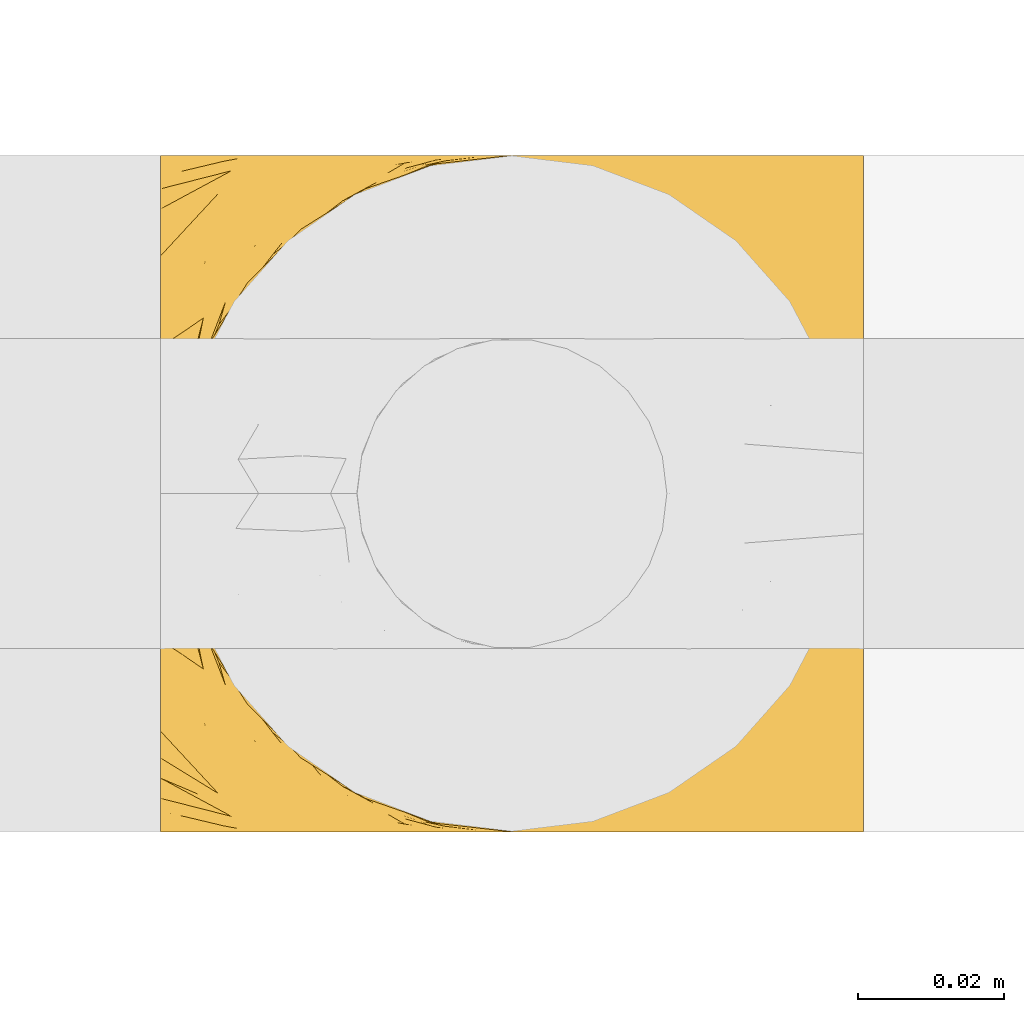
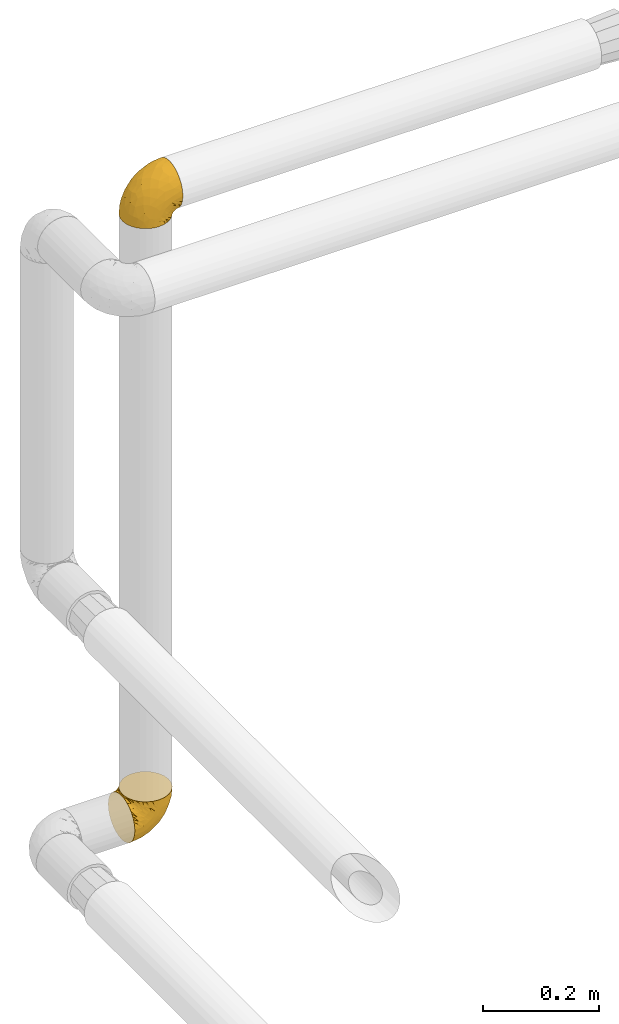
# One storey, part 132 of 827: 2 coverings.
"""IFC2X3 building model written with IfcOpenShell, lengths in millimetres."""

from ifc_helpers import new_model, entity, si_unit, converted_unit, derived_unit, direction, frame, origin, place, context, subcontext, project, spatial, faceted_brep, element, save


model = new_model("IFC2X3")

# Units and contexts
model_context = context("Model", 3, precision=0.01, world=origin(), true_north=direction((6.12303176911189e-17, 1.0)))
body_context = subcontext(model_context, "Body", "Model", "MODEL_VIEW")
ifc_project = project(units=[si_unit("LENGTHUNIT", "METRE", prefix="MILLI"), si_unit("AREAUNIT", "SQUARE_METRE"), si_unit("VOLUMEUNIT", "CUBIC_METRE"), converted_unit("PLANEANGLEUNIT", "DEGREE", entity("IfcRatioMeasure", 0.0174532925199433), si_unit("PLANEANGLEUNIT", "RADIAN"), dimensions=[0, 0, 0, 0, 0, 0, 0]), si_unit("MASSUNIT", "GRAM", prefix="KILO"), derived_unit("MASSDENSITYUNIT", [(si_unit("MASSUNIT", "GRAM", prefix="KILO"), 1), (si_unit("LENGTHUNIT", "METRE"), -3)]), derived_unit("MOMENTOFINERTIAUNIT", [(si_unit("LENGTHUNIT", "METRE"), 4)]), si_unit("TIMEUNIT", "SECOND"), si_unit("FREQUENCYUNIT", "HERTZ"), si_unit("THERMODYNAMICTEMPERATUREUNIT", "DEGREE_CELSIUS"), derived_unit("THERMALTRANSMITTANCEUNIT", [(si_unit("MASSUNIT", "GRAM", prefix="KILO"), 1), (si_unit("THERMODYNAMICTEMPERATUREUNIT", "KELVIN"), -1), (si_unit("TIMEUNIT", "SECOND"), -3)]), derived_unit("VOLUMETRICFLOWRATEUNIT", [(si_unit("LENGTHUNIT", "METRE"), 3), (si_unit("TIMEUNIT", "SECOND"), -1)]), derived_unit("MASSFLOWRATEUNIT", [(si_unit("MASSUNIT", "GRAM", prefix="KILO"), 1), (si_unit("TIMEUNIT", "SECOND"), -1)]), derived_unit("ROTATIONALFREQUENCYUNIT", [(si_unit("TIMEUNIT", "SECOND"), -1)]), si_unit("ELECTRICCURRENTUNIT", "AMPERE"), si_unit("ELECTRICVOLTAGEUNIT", "VOLT"), si_unit("POWERUNIT", "WATT"), si_unit("FORCEUNIT", "NEWTON", prefix="KILO"), si_unit("ILLUMINANCEUNIT", "LUX"), si_unit("LUMINOUSFLUXUNIT", "LUMEN"), si_unit("LUMINOUSINTENSITYUNIT", "CANDELA"), derived_unit("USERDEFINED", [(si_unit("MASSUNIT", "GRAM", prefix="KILO"), -1), (si_unit("LENGTHUNIT", "METRE"), -2), (si_unit("TIMEUNIT", "SECOND"), 3), (si_unit("LUMINOUSFLUXUNIT", "LUMEN"), 1)]), derived_unit("LINEARVELOCITYUNIT", [(si_unit("LENGTHUNIT", "METRE"), 1), (si_unit("TIMEUNIT", "SECOND"), -1)]), si_unit("PRESSUREUNIT", "PASCAL"), derived_unit("USERDEFINED", [(si_unit("LENGTHUNIT", "METRE"), -2), (si_unit("MASSUNIT", "GRAM", prefix="KILO"), 1), (si_unit("TIMEUNIT", "SECOND"), -2)]), derived_unit("LINEARFORCEUNIT", [(si_unit("MASSUNIT", "GRAM", prefix="KILO"), 1), (si_unit("LENGTHUNIT", "METRE"), 1), (si_unit("TIMEUNIT", "SECOND"), -2), (si_unit("LENGTHUNIT", "METRE"), -1)]), derived_unit("PLANARFORCEUNIT", [(si_unit("MASSUNIT", "GRAM", prefix="KILO"), 1), (si_unit("LENGTHUNIT", "METRE"), 1), (si_unit("TIMEUNIT", "SECOND"), -2), (si_unit("LENGTHUNIT", "METRE"), -2)])], contexts=[model_context])

# Site, building, storey
site_placement = place(None, origin())
site = spatial("IfcSite", under=ifc_project, at=site_placement, CompositionType="ELEMENT")
building_placement = place(site_placement, origin())
building = spatial("IfcBuilding", under=site, at=building_placement, CompositionType="ELEMENT")
storey_placement = place(building_placement, frame((0.0, 0.0, 28200.0)))
storey = spatial("IfcBuildingStorey", under=building, at=storey_placement, Name="08", CompositionType="ELEMENT", Elevation=28200.0)

# Coverings
covering_1_placement = place(storey_placement, frame((12158.15, 18965.67, 2950.4)))
element("IfcCovering", 1, at=covering_1_placement, inside=storey, Name=":ADSK_", ObjectType=":ADSK_", PredefinedType="INSULATION", context=body_context, shape_type="Brep", body=[
    faceted_brep([(18.98, 11.68, 1.6), (11.67, 19.0, 1.6), (6.17, 27.76, 1.6), (2.75, 37.52, 1.6), (1.6, 47.8, 1.6), (2.75, 58.08, 1.6), (6.17, 67.85, 1.6), (11.68, 76.61, 1.6), (19.0, 83.92, 1.6), (27.76, 89.42, 1.6), (37.52, 92.84, 1.6), (47.8, 94.0, 1.6), (51.94, 93.53, 1.6), (55.01, 93.18, 1.6), (58.08, 92.84, 1.6), (62.96, 91.13, 1.6), (67.85, 89.42, 1.6), (72.23, 86.66, 1.6), (76.61, 83.91, 1.6), (80.26, 80.25, 1.6), (83.92, 76.59, 1.6), (89.42, 67.83, 1.6), (91.13, 62.95, 1.6), (92.84, 58.07, 1.6), (94.0, 47.8, 1.6), (92.84, 37.51, 1.6), (91.13, 32.63, 1.6), (89.42, 27.74, 1.6), (83.91, 18.98, 1.6), (80.25, 15.33, 1.6), (76.59, 11.67, 1.6), (72.21, 8.92, 1.6), (67.83, 6.17, 1.6), (62.95, 4.46, 1.6), (58.07, 2.75, 1.6), (55.0, 2.41, 1.6), (51.94, 2.06, 1.6), (47.8, 1.6, 1.6), (37.51, 2.75, 1.6), (27.74, 6.17, 1.6), (95.8, 47.8, 3.4), (95.8, 59.75, 4.97), (95.8, 70.9, 9.58), (95.8, 75.68, 13.26), (95.8, 80.46, 16.93), (95.8, 84.13, 21.71), (95.8, 87.81, 26.5), (95.8, 90.11, 32.07), (95.8, 92.42, 37.64), (95.8, 92.9, 41.25), (95.8, 93.17, 43.34), (95.8, 93.45, 45.42), (95.8, 94.0, 49.6), (95.8, 92.42, 61.55), (95.8, 87.81, 72.7), (95.8, 80.46, 82.26), (95.8, 70.9, 89.61), (95.8, 59.75, 94.22), (95.8, 47.8, 95.8), (95.8, 35.84, 94.22), (95.8, 24.7, 89.61), (95.8, 15.13, 82.26), (95.8, 7.78, 72.7), (95.8, 3.17, 61.55), (95.8, 1.6, 49.6), (95.8, 2.14, 45.42), (95.8, 2.69, 41.25), (95.8, 3.17, 37.64), (95.8, 5.48, 32.07), (95.8, 7.78, 26.5), (95.8, 11.46, 21.71), (95.8, 15.13, 16.93), (95.8, 19.91, 13.26), (95.8, 24.7, 9.58), (95.8, 35.84, 4.97), (60.58, 23.61, 81.55), (74.11, 31.99, 90.4), (51.59, 35.87, 83.0), (66.69, 47.8, 91.18), (76.19, 40.43, 93.13), (84.43, 47.8, 94.0), (31.2, 31.83, 66.19), (42.88, 23.37, 70.92), (79.41, 21.41, 85.95), (60.7, 3.07, 49.74), (61.85, 1.6, 35.54), (65.75, 1.6, 38.14), (69.64, 1.6, 40.74), (73.53, 1.6, 43.34), (77.43, 1.6, 45.94), (74.59, 13.45, 77.59), (54.72, 15.25, 71.17), (64.18, 8.07, 65.81), (37.94, 16.0, 59.03), (25.89, 17.34, 45.85), (34.73, 10.58, 45.79), (42.89, 5.34, 41.42), (49.83, 2.39, 34.51), (48.58, 8.36, 56.04), (22.41, 10.04, 15.15), (78.69, 2.59, 56.51), (81.64, 6.28, 68.39), (6.22, 34.28, 23.33), (12.11, 38.73, 42.86), (14.81, 27.25, 39.42), (21.61, 29.88, 53.58), (22.41, 38.6, 59.17), (30.12, 23.44, 59.06), (10.01, 25.25, 22.63), (15.36, 17.23, 20.55), (3.39, 47.8, 12.96), (19.59, 47.8, 56.96), (30.01, 47.8, 67.38), (41.19, 2.53, 18.72), (48.54, 1.6, 5.33), (49.28, 1.6, 9.07), (49.82, 1.6, 11.79), (50.37, 1.6, 14.51), (50.91, 1.6, 17.24), (51.45, 1.6, 19.96), (31.61, 5.71, 21.03), (80.15, 1.6, 46.48), (82.88, 1.6, 47.03), (85.6, 1.6, 47.57), (88.32, 1.6, 48.11), (90.19, 1.6, 48.48), (92.06, 1.6, 48.85), (6.21, 47.8, 30.7), (54.05, 1.6, 23.86), (56.65, 1.6, 27.75), (59.25, 1.6, 31.64), (24.66, 11.89, 31.26), (40.43, 47.8, 77.8), (35.17, 39.69, 72.75), (12.9, 47.8, 43.83), (53.56, 47.8, 84.49), (85.34, 13.84, 14.58), (78.44, 9.16, 16.17), (84.37, 15.79, 10.82), (89.05, 25.75, 4.64), (82.76, 16.09, 7.71), (86.31, 7.51, 25.13), (83.73, 3.99, 32.66), (77.31, 2.66, 34.94), (87.78, 3.16, 36.76), (87.91, 2.35, 40.48), (81.29, 2.23, 39.25), (93.97, 38.35, 3.69), (70.76, 6.18, 13.99), (63.67, 2.7, 21.85), (62.62, 2.93, 17.93), (90.64, 16.01, 15.11), (84.08, 9.08, 21.14), (76.28, 9.3, 12.7), (77.45, 11.68, 7.21), (88.72, 4.65, 32.27), (71.28, 3.65, 25.68), (68.09, 3.61, 22.18), (91.07, 12.8, 18.79), (57.47, 2.43, 10.12), (70.34, 6.83, 9.47), (91.35, 21.65, 10.45), (62.99, 3.7, 11.29), (94.52, 47.8, 2.87), (76.47, 3.37, 31.16), (69.96, 7.03, 6.31), (89.86, 7.87, 25.62), (78.94, 7.26, 21.18), (73.51, 3.41, 28.81), (89.62, 23.81, 7.45), (84.09, 86.5, 21.14), (86.3, 88.08, 25.13), (91.06, 82.79, 18.79), (88.32, 94.0, 48.11), (92.06, 94.0, 48.85), (82.88, 94.0, 47.03), (85.6, 94.0, 47.57), (93.97, 57.24, 3.69), (89.63, 71.76, 7.44), (50.37, 94.0, 14.51), (49.82, 94.0, 11.79), (48.54, 94.0, 5.33), (49.28, 94.0, 9.07), (82.77, 79.49, 7.71), (70.36, 88.75, 9.47), (77.31, 92.93, 34.94), (76.47, 92.22, 31.16), (69.64, 94.0, 40.74), (65.75, 94.0, 38.14), (87.78, 92.43, 36.76), (87.91, 93.24, 40.48), (89.06, 69.82, 4.63), (90.65, 79.57, 15.11), (85.35, 81.74, 14.58), (73.53, 94.0, 43.34), (77.43, 94.0, 45.94), (81.29, 93.36, 39.25), (77.46, 83.9, 7.21), (76.29, 86.28, 12.69), (57.47, 93.16, 10.14), (63.71, 92.88, 21.81), (68.11, 91.98, 22.19), (70.77, 89.41, 14.0), (71.31, 91.93, 25.69), (78.46, 86.42, 16.17), (69.52, 88.82, 6.66), (62.64, 92.66, 17.92), (91.35, 73.93, 10.45), (59.25, 94.0, 31.64), (84.6, 79.5, 10.64), (62.98, 91.89, 11.31), (51.45, 94.0, 19.96), (54.05, 94.0, 23.86), (56.65, 94.0, 27.75), (83.73, 91.6, 32.66), (80.15, 94.0, 46.48), (88.72, 90.94, 32.27), (61.85, 94.0, 35.54), (73.56, 92.16, 28.77), (78.96, 88.32, 21.17), (91.36, 86.13, 23.36), (50.91, 94.0, 17.24), (62.87, 93.2, 47.58), (76.19, 55.16, 93.13), (73.57, 82.02, 77.44), (56.07, 84.29, 66.78), (49.77, 76.94, 71.68), (44.73, 68.33, 74.96), (60.58, 71.98, 81.55), (47.64, 92.52, 36.7), (78.32, 92.9, 56.9), (51.59, 59.72, 83.0), (74.11, 63.6, 90.4), (76.04, 88.89, 67.83), (79.41, 74.18, 85.95), (14.82, 68.35, 39.41), (6.22, 61.33, 23.33), (12.12, 56.86, 42.87), (23.51, 68.62, 53.92), (31.2, 63.76, 66.19), (34.96, 72.19, 64.12), (33.86, 88.69, 33.13), (38.94, 92.19, 23.1), (30.23, 89.75, 16.98), (20.67, 59.86, 55.72), (35.17, 55.9, 72.75), (15.85, 77.99, 23.77), (22.59, 85.21, 18.41), (21.56, 74.99, 43.7), (55.94, 90.23, 54.53), (9.19, 70.75, 17.73), (25.79, 81.72, 38.98), (41.16, 86.53, 50.28), (37.95, 79.6, 59.02)], [[[0, 1, 2, 3, 4, 5, 6, 7, 8, 9, 10, 11, 12, 13, 14, 15, 16, 17, 18, 19, 20, 21, 22, 23, 24, 25, 26, 27, 28, 29, 30, 31, 32, 33, 34, 35, 36, 37, 38, 39]], [[40, 41, 42, 43, 44, 45, 46, 47, 48, 49, 50, 51, 52, 53, 54, 55, 56, 57, 58, 59, 60, 61, 62, 63, 64, 65, 66, 67, 68, 69, 70, 71, 72, 73, 74]], [[75, 76, 77]], [[78, 79, 80]], [[77, 81, 82]], [[76, 75, 83]], [[84, 85, 86, 87, 88, 89]], [[90, 91, 92]], [[76, 60, 59]], [[93, 94, 95]], [[90, 62, 61]], [[83, 61, 60]], [[96, 97, 84]], [[98, 93, 95]], [[0, 39, 99]], [[100, 84, 89]], [[62, 101, 63]], [[2, 102, 3]], [[92, 84, 100]], [[103, 102, 104]], [[103, 105, 106]], [[93, 107, 94]], [[1, 108, 2]], [[92, 101, 90]], [[108, 1, 109]], [[102, 110, 3]], [[93, 82, 107]], [[102, 108, 104]], [[111, 106, 112]], [[109, 0, 99]], [[113, 37, 114, 115, 116, 117, 118, 119]], [[120, 38, 113]], [[100, 89, 121, 122, 123, 124, 125, 126, 64]], [[127, 102, 103]], [[97, 119, 128, 129, 130, 85]], [[99, 120, 131]], [[132, 133, 77]], [[59, 80, 79]], [[1, 0, 109]], [[98, 84, 92]], [[94, 109, 131]], [[120, 39, 38]], [[93, 91, 82]], [[104, 94, 105]], [[97, 113, 119]], [[95, 120, 96]], [[83, 90, 61]], [[91, 93, 98]], [[64, 63, 100]], [[100, 63, 101]], [[77, 76, 79]], [[133, 106, 81]], [[84, 97, 85]], [[113, 96, 120]], [[113, 97, 96]], [[37, 113, 38]], [[110, 102, 127]], [[110, 4, 3]], [[103, 111, 134, 127]], [[90, 75, 91]], [[82, 81, 107]], [[91, 75, 82]], [[77, 82, 75]], [[76, 83, 60]], [[90, 83, 75]], [[105, 107, 81]], [[94, 131, 95]], [[105, 94, 107]], [[109, 94, 104]], [[120, 95, 131]], [[98, 95, 96]], [[84, 98, 96]], [[98, 92, 91]], [[106, 105, 81]], [[103, 104, 105]], [[112, 106, 133]], [[103, 106, 111]], [[112, 133, 132]], [[81, 77, 133]], [[77, 78, 135, 132]], [[120, 99, 39]], [[109, 99, 131]], [[59, 58, 80]], [[59, 79, 76]], [[90, 101, 62]], [[100, 101, 92]], [[2, 108, 102]], [[109, 104, 108]], [[78, 77, 79]], [[136, 137, 138]], [[27, 139, 140]], [[141, 142, 143]], [[144, 145, 121]], [[146, 89, 88]], [[147, 139, 25]], [[148, 149, 150]], [[136, 151, 152]], [[147, 40, 74]], [[24, 147, 25]], [[140, 153, 154]], [[33, 116, 34]], [[73, 72, 151]], [[114, 37, 36, 35, 34, 116, 115]], [[146, 155, 144]], [[156, 85, 130]], [[157, 149, 148]], [[151, 158, 152]], [[117, 33, 159]], [[29, 154, 160]], [[161, 74, 73]], [[162, 128, 119]], [[66, 65, 64, 126, 125, 124, 123, 122, 67]], [[163, 147, 24]], [[27, 140, 28]], [[149, 129, 150]], [[139, 27, 26, 25]], [[68, 144, 69]], [[129, 128, 150]], [[164, 87, 86]], [[130, 129, 149]], [[122, 145, 67]], [[154, 153, 148]], [[162, 119, 159]], [[165, 30, 160]], [[150, 160, 148]], [[128, 162, 150]], [[30, 165, 31]], [[145, 144, 68]], [[89, 146, 144]], [[87, 164, 143]], [[166, 155, 142]], [[88, 87, 143]], [[162, 160, 150]], [[160, 30, 29]], [[154, 29, 28]], [[140, 154, 28]], [[160, 154, 148]], [[140, 137, 153]], [[157, 148, 153]], [[156, 130, 157]], [[153, 137, 157]], [[157, 137, 156]], [[167, 137, 136]], [[168, 85, 156]], [[152, 168, 167]], [[167, 168, 156]], [[164, 152, 141]], [[71, 158, 72]], [[152, 167, 136]], [[88, 142, 146]], [[144, 155, 69]], [[146, 142, 155]], [[70, 166, 71]], [[142, 141, 166]], [[70, 69, 155]], [[141, 158, 71]], [[161, 73, 151]], [[138, 137, 140]], [[161, 136, 169]], [[136, 161, 151]], [[74, 161, 169]], [[152, 158, 141]], [[151, 72, 158]], [[168, 152, 164]], [[137, 167, 156]], [[164, 86, 168]], [[85, 168, 86]], [[116, 33, 117]], [[130, 149, 157]], [[67, 145, 68]], [[121, 89, 144]], [[145, 122, 121]], [[40, 147, 163]], [[169, 147, 74]], [[159, 33, 32]], [[162, 159, 32]], [[159, 119, 118, 117]], [[139, 147, 169]], [[139, 169, 138]], [[162, 32, 31]], [[141, 143, 164]], [[88, 143, 142]], [[71, 166, 141]], [[155, 166, 70]], [[139, 138, 140]], [[169, 136, 138]], [[160, 162, 165]], [[162, 31, 165]], [[170, 171, 172]], [[173, 174, 52, 51, 50, 49, 48, 175, 176]], [[177, 178, 41]], [[179, 15, 180]], [[12, 11, 181, 182, 180, 14, 13]], [[183, 21, 20]], [[19, 18, 184]], [[185, 186, 187]], [[186, 188, 187]], [[43, 172, 44]], [[189, 190, 47]], [[23, 22, 21, 191]], [[170, 192, 193]], [[40, 163, 177]], [[194, 195, 196]], [[24, 23, 177]], [[197, 198, 183]], [[199, 15, 179]], [[47, 46, 189]], [[200, 201, 202]], [[201, 203, 204]], [[205, 206, 184]], [[207, 41, 178]], [[16, 15, 199]], [[14, 180, 15]], [[202, 201, 198]], [[208, 201, 200]], [[163, 24, 177]], [[48, 47, 190]], [[196, 195, 189]], [[197, 184, 202]], [[204, 193, 209]], [[210, 211, 212]], [[206, 212, 213]], [[205, 17, 210]], [[184, 206, 202]], [[210, 212, 206]], [[185, 194, 214]], [[189, 215, 190]], [[216, 45, 214]], [[186, 171, 170]], [[189, 216, 196]], [[197, 20, 19]], [[194, 185, 187]], [[197, 183, 20]], [[184, 197, 19]], [[197, 202, 198]], [[206, 200, 202]], [[204, 183, 198]], [[201, 208, 203]], [[203, 208, 217]], [[204, 198, 201]], [[217, 188, 218]], [[193, 219, 170]], [[171, 186, 185]], [[170, 218, 186]], [[170, 219, 218]], [[42, 207, 192]], [[171, 220, 172]], [[216, 189, 46]], [[214, 194, 196]], [[44, 220, 45]], [[214, 196, 216]], [[216, 46, 45]], [[214, 45, 220]], [[192, 43, 42]], [[204, 203, 219]], [[207, 193, 192]], [[209, 193, 178]], [[41, 207, 42]], [[193, 207, 178]], [[43, 192, 172]], [[170, 172, 192]], [[204, 219, 193]], [[219, 203, 218]], [[217, 218, 203]], [[188, 186, 218]], [[206, 213, 200]], [[208, 200, 213]], [[199, 210, 16]], [[215, 189, 195]], [[215, 175, 190]], [[175, 48, 190]], [[199, 179, 221, 211]], [[210, 199, 211]], [[23, 191, 177]], [[40, 177, 41]], [[178, 177, 191]], [[21, 183, 191]], [[209, 191, 183]], [[205, 18, 17]], [[17, 16, 210]], [[171, 185, 214]], [[172, 220, 44]], [[214, 220, 171]], [[191, 209, 178]], [[204, 209, 183]], [[206, 205, 210]], [[18, 205, 184]], [[222, 195, 194, 187, 188, 217]], [[57, 223, 80]], [[224, 225, 226]], [[226, 227, 228]], [[229, 217, 208, 213, 212, 211]], [[230, 52, 174, 173, 176, 175, 215, 195]], [[231, 232, 228]], [[231, 78, 223]], [[223, 57, 232]], [[224, 233, 225]], [[233, 54, 53]], [[234, 232, 56]], [[56, 55, 234]], [[234, 224, 228]], [[235, 236, 237]], [[224, 55, 54]], [[238, 239, 240]], [[52, 230, 53]], [[241, 242, 243]], [[239, 244, 245]], [[11, 10, 242]], [[236, 6, 5]], [[7, 246, 8]], [[8, 247, 9]], [[238, 248, 235]], [[222, 229, 249]], [[242, 211, 221, 179, 180, 182, 181, 11]], [[233, 53, 230]], [[111, 112, 244]], [[250, 6, 236]], [[247, 251, 241]], [[6, 250, 7]], [[127, 236, 110]], [[249, 229, 252]], [[247, 8, 246]], [[235, 246, 250]], [[236, 5, 110]], [[235, 244, 238]], [[237, 236, 127]], [[243, 9, 247]], [[252, 229, 241]], [[56, 232, 57]], [[222, 230, 195]], [[225, 249, 252]], [[249, 233, 230]], [[54, 233, 224]], [[231, 228, 227]], [[245, 132, 231]], [[249, 225, 233]], [[226, 225, 253]], [[235, 250, 236]], [[246, 7, 250]], [[251, 247, 246]], [[243, 247, 241]], [[248, 246, 235]], [[252, 251, 253]], [[229, 222, 217]], [[230, 222, 249]], [[5, 4, 110]], [[237, 127, 134, 111]], [[238, 244, 239]], [[224, 234, 55]], [[232, 234, 228]], [[242, 241, 229]], [[10, 9, 243]], [[211, 242, 229]], [[10, 243, 242]], [[80, 223, 78]], [[80, 58, 57]], [[231, 223, 232]], [[227, 240, 239]], [[224, 226, 228]], [[240, 226, 253]], [[227, 239, 245]], [[226, 240, 227]], [[251, 248, 253]], [[240, 253, 248]], [[244, 235, 237]], [[237, 111, 244]], [[132, 245, 112]], [[112, 245, 244]], [[135, 78, 231, 132]], [[227, 245, 231]], [[248, 238, 240]], [[246, 248, 251]], [[251, 252, 241]], [[225, 252, 253]]]),
])
covering_2_placement = place(storey_placement, frame((12156.35, 18965.67, 1646.47)))
element("IfcCovering", 2, at=covering_2_placement, inside=storey, Name=":ADSK_", ObjectType=":ADSK_", PredefinedType="INSULATION", context=body_context, shape_type="Brep", body=[
    faceted_brep([(1.6, 83.91, 18.98), (1.6, 76.59, 11.67), (1.6, 67.83, 6.17), (1.6, 58.07, 2.75), (1.6, 47.8, 1.6), (1.6, 37.51, 2.75), (1.6, 27.74, 6.17), (1.6, 18.98, 11.68), (1.6, 11.67, 19.0), (1.6, 6.17, 27.76), (1.6, 2.75, 37.52), (1.6, 1.6, 47.8), (1.6, 2.06, 51.94), (1.6, 2.41, 55.01), (1.6, 2.75, 58.08), (1.6, 4.46, 62.96), (1.6, 6.17, 67.85), (1.6, 8.93, 72.23), (1.6, 11.68, 76.61), (1.6, 15.34, 80.26), (1.6, 19.0, 83.92), (1.6, 27.76, 89.42), (1.6, 32.64, 91.13), (1.6, 37.52, 92.84), (1.6, 47.8, 94.0), (1.6, 58.08, 92.84), (1.6, 62.96, 91.13), (1.6, 67.85, 89.42), (1.6, 76.61, 83.91), (1.6, 80.26, 80.25), (1.6, 83.92, 76.59), (1.6, 86.67, 72.21), (1.6, 89.42, 67.83), (1.6, 91.13, 62.95), (1.6, 92.84, 58.07), (1.6, 93.18, 55.0), (1.6, 93.53, 51.94), (1.6, 94.0, 47.8), (1.6, 92.84, 37.51), (1.6, 89.42, 27.74), (3.4, 47.8, 95.8), (4.97, 35.84, 95.8), (9.58, 24.7, 95.8), (13.26, 19.91, 95.8), (16.93, 15.13, 95.8), (21.71, 11.46, 95.8), (26.5, 7.78, 95.8), (32.07, 5.48, 95.8), (37.64, 3.17, 95.8), (41.25, 2.69, 95.8), (43.34, 2.42, 95.8), (45.42, 2.14, 95.8), (49.6, 1.6, 95.8), (61.55, 3.17, 95.8), (72.7, 7.78, 95.8), (82.26, 15.13, 95.8), (89.61, 24.7, 95.8), (94.22, 35.84, 95.8), (95.8, 47.8, 95.8), (94.22, 59.75, 95.8), (89.61, 70.9, 95.8), (82.26, 80.46, 95.8), (72.7, 87.81, 95.8), (61.55, 92.42, 95.8), (49.6, 94.0, 95.8), (45.42, 93.45, 95.8), (41.25, 92.9, 95.8), (37.64, 92.42, 95.8), (32.07, 90.11, 95.8), (26.5, 87.81, 95.8), (21.71, 84.13, 95.8), (16.93, 80.46, 95.8), (13.26, 75.68, 95.8), (9.58, 70.9, 95.8), (4.97, 59.75, 95.8), (81.55, 71.98, 60.58), (90.4, 63.6, 74.11), (83.0, 59.72, 51.59), (91.18, 47.8, 66.69), (93.13, 55.16, 76.19), (94.0, 47.8, 84.43), (66.19, 63.76, 31.2), (70.92, 72.22, 42.88), (85.95, 74.18, 79.41), (49.74, 92.52, 60.7), (35.54, 94.0, 61.85), (38.14, 94.0, 65.75), (40.74, 94.0, 69.64), (43.34, 94.0, 73.53), (45.94, 94.0, 77.43), (77.59, 82.14, 74.59), (71.17, 80.34, 54.72), (65.81, 87.52, 64.18), (59.03, 79.59, 37.94), (45.85, 78.25, 25.89), (45.79, 85.01, 34.73), (41.42, 90.25, 42.89), (34.51, 93.2, 49.83), (56.04, 87.23, 48.58), (15.15, 85.55, 22.41), (56.51, 93.0, 78.69), (68.39, 89.31, 81.64), (23.33, 61.31, 6.22), (42.86, 56.86, 12.11), (39.42, 68.34, 14.81), (53.58, 65.71, 21.61), (59.17, 56.99, 22.41), (59.06, 72.15, 30.12), (22.63, 70.34, 10.01), (20.55, 78.36, 15.36), (12.96, 47.8, 3.39), (56.96, 47.8, 19.59), (67.38, 47.8, 30.01), (18.72, 93.06, 41.19), (5.33, 94.0, 48.54), (9.07, 94.0, 49.28), (11.79, 94.0, 49.82), (14.51, 94.0, 50.37), (17.24, 94.0, 50.91), (19.96, 94.0, 51.45), (21.03, 89.88, 31.61), (46.48, 94.0, 80.15), (47.03, 94.0, 82.88), (47.57, 94.0, 85.6), (48.11, 94.0, 88.32), (48.48, 94.0, 90.19), (48.85, 94.0, 92.06), (30.7, 47.8, 6.21), (23.86, 94.0, 54.05), (27.75, 94.0, 56.65), (31.64, 94.0, 59.25), (31.26, 83.7, 24.66), (77.8, 47.8, 40.43), (72.75, 55.9, 35.17), (43.83, 47.8, 12.9), (84.49, 47.8, 53.56), (14.58, 81.75, 85.34), (16.17, 86.43, 78.44), (10.82, 79.8, 84.37), (4.64, 69.84, 89.05), (7.71, 79.5, 82.76), (25.13, 88.08, 86.31), (32.66, 91.6, 83.73), (34.94, 92.93, 77.31), (36.76, 92.43, 87.78), (40.48, 93.24, 87.91), (39.25, 93.36, 81.29), (3.69, 57.25, 93.97), (13.99, 89.41, 70.76), (21.85, 92.89, 63.67), (17.93, 92.66, 62.62), (15.11, 79.58, 90.64), (21.14, 86.51, 84.08), (7.21, 83.91, 77.45), (9.47, 88.76, 70.34), (32.27, 90.94, 88.72), (25.68, 91.94, 71.28), (22.18, 91.98, 68.09), (18.79, 82.79, 91.07), (10.12, 93.16, 57.47), (10.45, 73.94, 91.35), (11.29, 91.89, 62.99), (2.87, 47.8, 94.52), (31.16, 92.22, 76.47), (12.7, 86.29, 76.28), (6.31, 88.56, 69.96), (25.62, 87.72, 89.86), (21.18, 88.33, 78.94), (28.81, 92.18, 73.51), (7.45, 71.78, 89.62), (21.14, 9.09, 84.09), (25.13, 7.51, 86.3), (18.79, 12.8, 91.06), (48.11, 1.6, 88.32), (48.85, 1.6, 92.06), (47.03, 1.6, 82.88), (47.57, 1.6, 85.6), (3.69, 38.35, 93.97), (7.44, 23.84, 89.63), (14.51, 1.6, 50.37), (11.79, 1.6, 49.82), (5.33, 1.6, 48.54), (9.07, 1.6, 49.28), (7.71, 16.1, 82.77), (9.47, 6.84, 70.36), (34.94, 2.66, 77.31), (31.16, 3.37, 76.47), (40.74, 1.6, 69.64), (38.14, 1.6, 65.75), (36.76, 3.16, 87.78), (40.48, 2.35, 87.91), (4.63, 25.77, 89.06), (15.11, 16.02, 90.65), (14.58, 13.85, 85.35), (43.34, 1.6, 73.53), (45.94, 1.6, 77.43), (39.25, 2.23, 81.29), (7.21, 11.69, 77.46), (12.69, 9.31, 76.29), (10.14, 2.43, 57.47), (21.81, 2.71, 63.71), (22.19, 3.61, 68.11), (14.0, 6.18, 70.77), (25.69, 3.66, 71.31), (16.17, 9.17, 78.46), (6.66, 6.77, 69.52), (17.92, 2.93, 62.64), (10.45, 21.66, 91.35), (31.64, 1.6, 59.25), (10.64, 16.09, 84.6), (11.31, 3.7, 62.98), (19.96, 1.6, 51.45), (23.86, 1.6, 54.05), (27.75, 1.6, 56.65), (32.66, 3.99, 83.73), (46.48, 1.6, 80.15), (32.27, 4.65, 88.72), (35.54, 1.6, 61.85), (28.77, 3.43, 73.56), (21.17, 7.27, 78.96), (23.36, 9.46, 91.36), (17.24, 1.6, 50.91), (47.58, 2.4, 62.87), (93.13, 40.43, 76.19), (77.44, 13.57, 73.57), (66.78, 11.3, 56.07), (71.68, 18.65, 49.77), (74.96, 27.26, 44.73), (81.55, 23.61, 60.58), (36.7, 3.07, 47.64), (56.9, 2.69, 78.32), (83.0, 35.87, 51.59), (90.4, 31.99, 74.11), (67.83, 6.71, 76.04), (85.95, 21.41, 79.41), (39.41, 27.24, 14.82), (23.33, 34.26, 6.22), (42.87, 38.73, 12.12), (53.92, 26.97, 23.51), (66.19, 31.83, 31.2), (64.12, 23.4, 34.96), (33.13, 6.91, 33.86), (23.1, 3.4, 38.94), (16.98, 5.84, 30.23), (55.72, 35.73, 20.67), (72.75, 39.69, 35.17), (23.77, 17.6, 15.85), (18.41, 10.38, 22.59), (43.7, 20.6, 21.56), (54.53, 5.36, 55.94), (17.73, 24.84, 9.19), (38.98, 13.87, 25.79), (50.28, 9.06, 41.16), (59.02, 15.99, 37.95)], [[[0, 1, 2, 3, 4, 5, 6, 7, 8, 9, 10, 11, 12, 13, 14, 15, 16, 17, 18, 19, 20, 21, 22, 23, 24, 25, 26, 27, 28, 29, 30, 31, 32, 33, 34, 35, 36, 37, 38, 39]], [[40, 41, 42, 43, 44, 45, 46, 47, 48, 49, 50, 51, 52, 53, 54, 55, 56, 57, 58, 59, 60, 61, 62, 63, 64, 65, 66, 67, 68, 69, 70, 71, 72, 73, 74]], [[75, 76, 77]], [[78, 79, 80]], [[77, 81, 82]], [[76, 75, 83]], [[84, 85, 86, 87, 88, 89]], [[90, 91, 92]], [[76, 60, 59]], [[93, 94, 95]], [[90, 62, 61]], [[83, 61, 60]], [[96, 97, 84]], [[98, 93, 95]], [[0, 39, 99]], [[100, 84, 89]], [[62, 101, 63]], [[2, 102, 3]], [[92, 84, 100]], [[103, 102, 104]], [[103, 105, 106]], [[93, 107, 94]], [[1, 108, 2]], [[92, 101, 90]], [[108, 1, 109]], [[102, 110, 3]], [[93, 82, 107]], [[102, 108, 104]], [[111, 106, 112]], [[109, 0, 99]], [[113, 37, 114, 115, 116, 117, 118, 119]], [[120, 38, 113]], [[100, 89, 121, 122, 123, 124, 125, 126, 64]], [[127, 102, 103]], [[97, 119, 128, 129, 130, 85]], [[99, 120, 131]], [[132, 133, 77]], [[59, 80, 79]], [[1, 0, 109]], [[98, 84, 92]], [[94, 109, 131]], [[120, 39, 38]], [[93, 91, 82]], [[104, 94, 105]], [[97, 113, 119]], [[95, 120, 96]], [[83, 90, 61]], [[91, 93, 98]], [[64, 63, 100]], [[100, 63, 101]], [[77, 76, 79]], [[133, 106, 81]], [[84, 97, 85]], [[113, 96, 120]], [[113, 97, 96]], [[37, 113, 38]], [[110, 102, 127]], [[110, 4, 3]], [[103, 111, 134, 127]], [[90, 75, 91]], [[82, 81, 107]], [[91, 75, 82]], [[77, 82, 75]], [[76, 83, 60]], [[90, 83, 75]], [[105, 107, 81]], [[94, 131, 95]], [[105, 94, 107]], [[109, 94, 104]], [[120, 95, 131]], [[98, 95, 96]], [[84, 98, 96]], [[98, 92, 91]], [[106, 105, 81]], [[103, 104, 105]], [[112, 106, 133]], [[103, 106, 111]], [[112, 133, 132]], [[81, 77, 133]], [[77, 78, 135, 132]], [[120, 99, 39]], [[109, 99, 131]], [[59, 58, 80]], [[59, 79, 76]], [[90, 101, 62]], [[100, 101, 92]], [[2, 108, 102]], [[109, 104, 108]], [[78, 77, 79]], [[136, 137, 138]], [[27, 139, 140]], [[141, 142, 143]], [[144, 145, 121]], [[146, 89, 88]], [[147, 139, 25]], [[148, 149, 150]], [[136, 151, 152]], [[147, 40, 74]], [[24, 147, 25]], [[153, 148, 154]], [[33, 116, 34]], [[73, 72, 151]], [[114, 37, 36, 35, 34, 116, 115]], [[146, 155, 144]], [[156, 85, 130]], [[157, 149, 148]], [[151, 158, 152]], [[117, 33, 159]], [[29, 153, 154]], [[160, 74, 73]], [[161, 128, 119]], [[66, 65, 64, 126, 125, 124, 123, 122, 67]], [[162, 147, 24]], [[27, 140, 28]], [[149, 129, 150]], [[139, 27, 26, 25]], [[68, 144, 69]], [[129, 128, 150]], [[163, 87, 86]], [[130, 129, 149]], [[122, 145, 67]], [[153, 164, 148]], [[161, 119, 159]], [[165, 30, 154]], [[150, 154, 148]], [[128, 161, 150]], [[30, 165, 31]], [[145, 144, 68]], [[89, 146, 144]], [[87, 163, 143]], [[166, 155, 142]], [[88, 87, 143]], [[161, 154, 150]], [[154, 30, 29]], [[29, 28, 153]], [[28, 140, 153]], [[164, 153, 140]], [[140, 137, 164]], [[157, 148, 164]], [[156, 130, 157]], [[164, 137, 157]], [[157, 137, 156]], [[167, 137, 136]], [[168, 85, 156]], [[152, 168, 167]], [[167, 168, 156]], [[163, 152, 141]], [[71, 158, 72]], [[152, 167, 136]], [[88, 142, 146]], [[144, 155, 69]], [[146, 142, 155]], [[70, 166, 71]], [[142, 141, 166]], [[70, 69, 155]], [[141, 158, 71]], [[160, 73, 151]], [[138, 137, 140]], [[160, 136, 169]], [[136, 160, 151]], [[74, 160, 169]], [[152, 158, 141]], [[151, 72, 158]], [[168, 152, 163]], [[137, 167, 156]], [[163, 86, 168]], [[85, 168, 86]], [[116, 33, 117]], [[130, 149, 157]], [[67, 145, 68]], [[121, 89, 144]], [[145, 122, 121]], [[40, 147, 162]], [[169, 147, 74]], [[159, 33, 32]], [[161, 159, 32]], [[159, 119, 118, 117]], [[139, 147, 169]], [[139, 169, 138]], [[161, 32, 31]], [[141, 143, 163]], [[88, 143, 142]], [[71, 166, 141]], [[155, 166, 70]], [[139, 138, 140]], [[169, 136, 138]], [[154, 161, 165]], [[161, 31, 165]], [[170, 171, 172]], [[173, 174, 52, 51, 50, 49, 48, 175, 176]], [[177, 178, 41]], [[179, 15, 180]], [[12, 11, 181, 182, 180, 14, 13]], [[183, 21, 20]], [[19, 18, 184]], [[185, 186, 187]], [[186, 188, 187]], [[43, 172, 44]], [[189, 190, 47]], [[23, 22, 21, 191]], [[170, 192, 193]], [[40, 162, 177]], [[194, 195, 196]], [[24, 23, 177]], [[197, 198, 183]], [[199, 15, 179]], [[47, 46, 189]], [[200, 201, 202]], [[201, 203, 204]], [[205, 206, 184]], [[207, 41, 178]], [[16, 15, 199]], [[14, 180, 15]], [[202, 201, 198]], [[208, 201, 200]], [[162, 24, 177]], [[48, 47, 190]], [[196, 195, 189]], [[197, 184, 202]], [[204, 193, 209]], [[210, 211, 212]], [[206, 212, 213]], [[205, 17, 210]], [[184, 206, 202]], [[210, 212, 206]], [[185, 194, 214]], [[189, 215, 190]], [[216, 45, 214]], [[186, 171, 170]], [[189, 216, 196]], [[197, 20, 19]], [[194, 185, 187]], [[197, 183, 20]], [[184, 197, 19]], [[197, 202, 198]], [[206, 200, 202]], [[204, 183, 198]], [[201, 208, 203]], [[203, 208, 217]], [[204, 198, 201]], [[217, 188, 218]], [[193, 219, 170]], [[171, 186, 185]], [[170, 218, 186]], [[170, 219, 218]], [[42, 207, 192]], [[171, 220, 172]], [[216, 189, 46]], [[214, 194, 196]], [[44, 220, 45]], [[214, 196, 216]], [[216, 46, 45]], [[214, 45, 220]], [[192, 43, 42]], [[204, 203, 219]], [[207, 193, 192]], [[209, 193, 178]], [[41, 207, 42]], [[193, 207, 178]], [[43, 192, 172]], [[170, 172, 192]], [[204, 219, 193]], [[219, 203, 218]], [[217, 218, 203]], [[188, 186, 218]], [[206, 213, 200]], [[208, 200, 213]], [[199, 210, 16]], [[215, 189, 195]], [[215, 175, 190]], [[175, 48, 190]], [[199, 179, 221, 211]], [[210, 199, 211]], [[23, 191, 177]], [[40, 177, 41]], [[183, 209, 191]], [[183, 191, 21]], [[191, 178, 177]], [[205, 18, 17]], [[17, 16, 210]], [[171, 185, 214]], [[172, 220, 44]], [[214, 220, 171]], [[191, 209, 178]], [[204, 209, 183]], [[206, 205, 210]], [[18, 205, 184]], [[222, 195, 194, 187, 188, 217]], [[57, 223, 80]], [[224, 225, 226]], [[226, 227, 228]], [[229, 217, 208, 213, 212, 211]], [[230, 52, 174, 173, 176, 175, 215, 195]], [[231, 232, 228]], [[231, 78, 223]], [[223, 57, 232]], [[224, 233, 225]], [[233, 54, 53]], [[234, 232, 56]], [[56, 55, 234]], [[234, 224, 228]], [[235, 236, 237]], [[224, 55, 54]], [[238, 239, 240]], [[52, 230, 53]], [[241, 242, 243]], [[239, 244, 245]], [[11, 10, 242]], [[236, 6, 5]], [[7, 246, 8]], [[8, 247, 9]], [[238, 248, 235]], [[222, 229, 249]], [[242, 211, 221, 179, 180, 182, 181, 11]], [[233, 53, 230]], [[111, 112, 244]], [[250, 6, 236]], [[247, 251, 241]], [[6, 250, 7]], [[127, 236, 110]], [[249, 229, 252]], [[247, 8, 246]], [[235, 246, 250]], [[236, 5, 110]], [[235, 244, 238]], [[237, 236, 127]], [[243, 9, 247]], [[252, 229, 241]], [[56, 232, 57]], [[222, 230, 195]], [[225, 249, 252]], [[249, 233, 230]], [[54, 233, 224]], [[231, 228, 227]], [[245, 132, 231]], [[249, 225, 233]], [[226, 225, 253]], [[235, 250, 236]], [[246, 7, 250]], [[251, 247, 246]], [[243, 247, 241]], [[248, 246, 235]], [[252, 251, 253]], [[229, 222, 217]], [[230, 222, 249]], [[5, 4, 110]], [[237, 127, 134, 111]], [[238, 244, 239]], [[224, 234, 55]], [[232, 234, 228]], [[242, 241, 229]], [[10, 9, 243]], [[211, 242, 229]], [[10, 243, 242]], [[80, 223, 78]], [[80, 58, 57]], [[231, 223, 232]], [[227, 240, 239]], [[224, 226, 228]], [[240, 226, 253]], [[227, 239, 245]], [[226, 240, 227]], [[251, 248, 253]], [[240, 253, 248]], [[244, 235, 237]], [[237, 111, 244]], [[132, 245, 112]], [[112, 245, 244]], [[135, 78, 231, 132]], [[227, 245, 231]], [[248, 238, 240]], [[246, 248, 251]], [[251, 252, 241]], [[225, 252, 253]]]),
])

save(model, "model.ifc")
